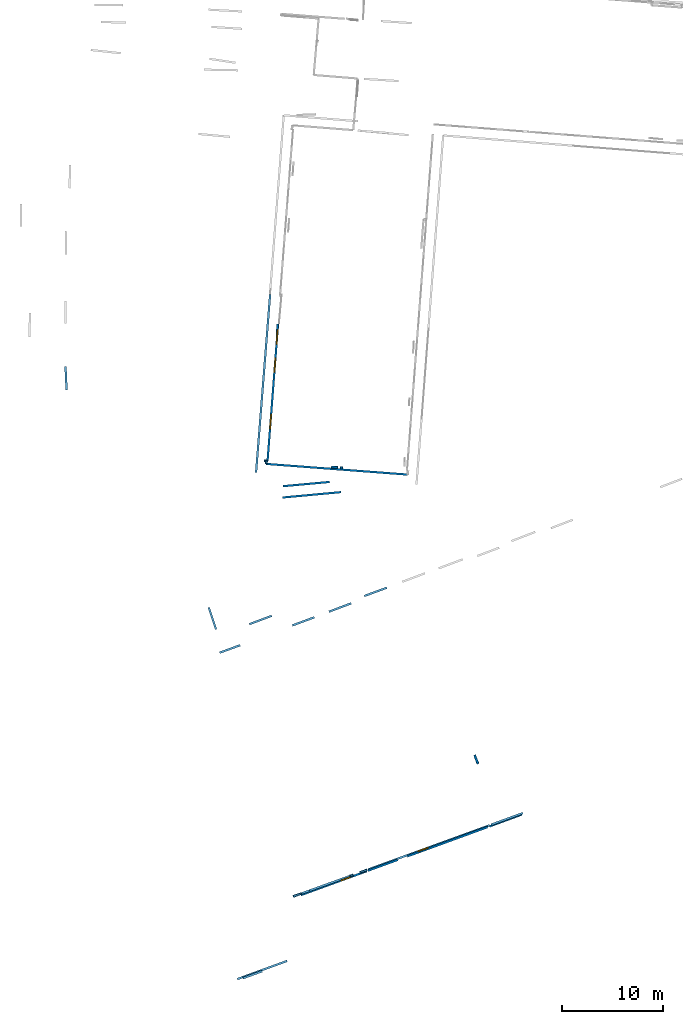
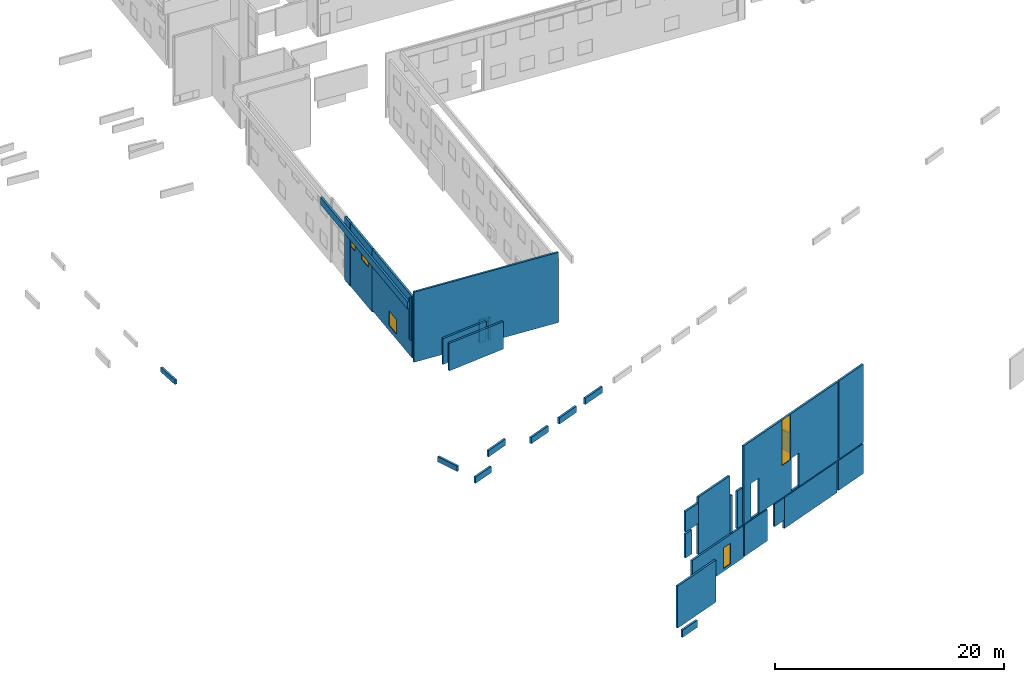
# One storey, part 1 of 27: 33 walls, 5 windows, 7 openings.
"""IFC2X3 building model written with IfcOpenShell, lengths in metres."""

from ifc_helpers import new_model, entity, si_unit, converted_unit, derived_unit, direction, frame, frame_2d, origin, origin_2d_with_axis, place, context, subcontext, project, spatial, polyline, rectangle, outline, extrude, source, transform, mapped, material, layer, layer_set, layer_usage, type_object, type_shapes, element, fill, save


model = new_model("IFC2X3")

# Units and contexts
model_context = context("Model", 3, precision=1e-05, world=origin(), true_north=direction((0.0, 1.0)))
body_context = subcontext(model_context, "Body", "Model", "MODEL_VIEW")
ifc_project = project(units=[si_unit("LENGTHUNIT", "METRE"), si_unit("AREAUNIT", "SQUARE_METRE"), si_unit("VOLUMEUNIT", "CUBIC_METRE"), converted_unit("PLANEANGLEUNIT", "DEGREE", entity("IfcRatioMeasure", 0.0174532925199433), si_unit("PLANEANGLEUNIT", "RADIAN"), dimensions=[0, 0, 0, 0, 0, 0, 0]), si_unit("MASSUNIT", "GRAM", prefix="KILO"), derived_unit("MASSDENSITYUNIT", [(si_unit("MASSUNIT", "GRAM", prefix="KILO"), 1), (si_unit("LENGTHUNIT", "METRE"), -3)]), derived_unit("MOMENTOFINERTIAUNIT", [(si_unit("LENGTHUNIT", "METRE"), 4)]), si_unit("TIMEUNIT", "SECOND"), si_unit("FREQUENCYUNIT", "HERTZ"), si_unit("THERMODYNAMICTEMPERATUREUNIT", "DEGREE_CELSIUS"), derived_unit("THERMALTRANSMITTANCEUNIT", [(si_unit("MASSUNIT", "GRAM", prefix="KILO"), 1), (si_unit("THERMODYNAMICTEMPERATUREUNIT", "KELVIN"), -1), (si_unit("TIMEUNIT", "SECOND"), -3)]), derived_unit("VOLUMETRICFLOWRATEUNIT", [(si_unit("LENGTHUNIT", "METRE"), 3), (si_unit("TIMEUNIT", "SECOND"), -1)]), si_unit("ELECTRICCURRENTUNIT", "AMPERE"), si_unit("ELECTRICVOLTAGEUNIT", "VOLT"), si_unit("POWERUNIT", "WATT"), si_unit("FORCEUNIT", "NEWTON", prefix="KILO"), si_unit("ILLUMINANCEUNIT", "LUX"), si_unit("LUMINOUSFLUXUNIT", "LUMEN"), si_unit("LUMINOUSINTENSITYUNIT", "CANDELA"), derived_unit("USERDEFINED", [(si_unit("MASSUNIT", "GRAM", prefix="KILO"), -1), (si_unit("LENGTHUNIT", "METRE"), -2), (si_unit("TIMEUNIT", "SECOND"), 3), (si_unit("LUMINOUSFLUXUNIT", "LUMEN"), 1)]), derived_unit("LINEARVELOCITYUNIT", [(si_unit("LENGTHUNIT", "METRE"), 1), (si_unit("TIMEUNIT", "SECOND"), -1)]), si_unit("PRESSUREUNIT", "PASCAL"), derived_unit("USERDEFINED", [(si_unit("LENGTHUNIT", "METRE"), -2), (si_unit("MASSUNIT", "GRAM", prefix="KILO"), 1), (si_unit("TIMEUNIT", "SECOND"), -2)]), derived_unit("LINEARFORCEUNIT", [(si_unit("MASSUNIT", "GRAM", prefix="KILO"), 1), (si_unit("LENGTHUNIT", "METRE"), 1), (si_unit("TIMEUNIT", "SECOND"), -2), (si_unit("LENGTHUNIT", "METRE"), -1)]), derived_unit("PLANARFORCEUNIT", [(si_unit("MASSUNIT", "GRAM", prefix="KILO"), 1), (si_unit("LENGTHUNIT", "METRE"), 1), (si_unit("TIMEUNIT", "SECOND"), -2), (si_unit("LENGTHUNIT", "METRE"), -2)])], contexts=[model_context])

# Site, building, storey
placement_1 = place(None, origin())
site = spatial("IfcSite", under=ifc_project, at=placement_1, CompositionType="ELEMENT")
building = spatial("IfcBuilding", under=site, at=placement_1, CompositionType="ELEMENT")
storey_placement = place(placement_1, frame((0.0, 0.0, -61.043098449707)))
storey = spatial("IfcBuildingStorey", under=building, at=storey_placement, Name="level_-61.043098", CompositionType="ELEMENT", Elevation=-61.043098449707)

# Walls
ifc_material_1 = material(Name="Default wall")
ifc_layer = layer(ifc_material_1, 0.2)
ifc_layer_set = layer_set([ifc_layer], Name="wall_thickness_0.2000")
ifc_layer_usage = layer_usage(ifc_layer_set, "AXIS2", "POSITIVE", -0.1)
wall_type = type_object("IfcWallType", Name="wall_thickness_0.2000", PredefinedType="STANDARD", material=ifc_layer_set)
placement_2 = place(placement_1, frame((0.0, 0.0, -60.9578857421875)))
wall_1_placement = place(placement_2, frame((-80.6177598046556, -47.234106704817, 0.0), z_axis=(0.0, 0.0, 1.0), x_axis=(-0.997479703780605, 0.0709523822415854, 0.0)))
element("IfcWallStandardCase", 1, at=wall_1_placement, inside=storey, type_object=wall_type, material=ifc_layer_usage, Name="Wall:151", ObjectType="Wall", context=body_context, shape_type="SweptSolid", body=[
    extrude(outline(polyline([(0.230003199142466, -0.1), (0.230003199142466, 0.1), (0.0, 0.1), (0.0, -0.1), (0.230003199142466, -0.1)])), origin(), (0.0, 0.0, 1.0), 2.42822265625),
])
placement_3 = place(placement_1, frame((0.0, 0.0, -60.8847198486328)))
wall_2_placement = place(placement_3, frame((-108.021425655516, -37.2043182576579, 0.0), z_axis=(0.0, 0.0, 1.0), x_axis=(0.0460349743108002, -0.998939828588391, 0.0)))
element("IfcWallStandardCase", 2, at=wall_2_placement, inside=storey, type_object=wall_type, material=ifc_layer_usage, Name="Wall:236", ObjectType="Wall", context=body_context, shape_type="SweptSolid", body=[
    extrude(outline(polyline([(2.31508790441592, -0.1), (2.31508790441592, 0.1), (0.0, 0.1), (0.0, -0.1), (2.31508790441592, -0.1)])), origin(), (0.0, 0.0, 1.0), 0.486675262451172),
])
placement_4 = place(placement_1, frame((0.0, 0.0, -58.6692237854004)))
wall_3_placement = place(placement_4, frame((-90.4635958246936, -97.7054273782261, 0.0), z_axis=(0.0, 0.0, 1.0), x_axis=(0.939621098176987, 0.342216586185814, 0.0)))
element("IfcWallStandardCase", 3, at=wall_3_placement, inside=storey, type_object=wall_type, material=ifc_layer_usage, Name="Wall:272", ObjectType="Wall", context=body_context, shape_type="SweptSolid", body=[
    extrude(outline(polyline([(2.00499331555158, -0.1), (2.00499331555158, 0.1), (0.0, 0.1), (0.0, -0.1), (2.00499331555158, -0.1)])), origin(), (0.0, 0.0, 1.0), 0.768932342529297),
])
placement_5 = place(placement_1, frame((0.0, 0.0, -56.8473930358887)))
wall_4_placement = place(placement_5, frame((-84.6901072986257, -89.3302330235321, 0.0), z_axis=(0.0, 0.0, 1.0), x_axis=(-0.940651161768594, -0.339375001824521, 0.0)))
element("IfcWallStandardCase", 4, at=wall_4_placement, inside=storey, type_object=wall_type, material=ifc_layer_usage, Name="Wall:330", ObjectType="Wall", context=body_context, shape_type="SweptSolid", body=[
    extrude(outline(polyline([(0.859999959407384, -0.1), (0.859999959407384, 0.1), (0.0, 0.1), (0.0, -0.1), (0.859999959407384, -0.1)])), origin(), (0.0, 0.0, 1.0), 2.56648635864258),
])
placement_6 = place(placement_1, frame((0.0, 0.0, -54.077392578125)))
wall_5_placement = place(placement_6, frame((-83.8764476306569, -89.0366691807587, 0.0), z_axis=(0.0, 0.0, 1.0), x_axis=(-0.940650301479589, -0.339377386291954, 0.0)))
element("IfcWallStandardCase", 5, at=wall_5_placement, inside=storey, type_object=wall_type, material=ifc_layer_usage, Name="Wall:332", ObjectType="Wall", context=body_context, shape_type="SweptSolid", body=[
    extrude(outline(polyline([(1.71499714921871, -0.1), (1.71499714921871, 0.1), (0.0, 0.1), (0.0, -0.1), (1.71499714921871, -0.1)])), origin(), (0.0, 0.0, 1.0), 2.18500137329102),
])
placement_7 = place(placement_1, frame((0.0, 0.0, -57.3973922729492)))
wall_6_placement = place(placement_7, frame((-79.8645762927663, -87.5892128208954, 0.0), z_axis=(0.0, 0.0, 1.0), x_axis=(-0.940649358342172, -0.339380000368998, 0.0)))
element("IfcWallStandardCase", 6, at=wall_6_placement, inside=storey, type_object=wall_type, material=ifc_layer_usage, Name="Wall:333", ObjectType="Wall", context=body_context, shape_type="SweptSolid", body=[
    extrude(outline(polyline([(4.26500193968267, -0.1), (4.26500193968267, 0.1), (0.0, 0.1), (0.0, -0.1), (4.26500193968267, -0.1)])), origin(), (0.0, 0.0, 1.0), 6.125),
])
placement_8 = place(placement_1, frame((0.0, 0.0, -57.4490737915039)))
wall_7_placement = place(placement_8, frame((-62.7970209183944, -81.3764209561319, 0.0), z_axis=(0.0, 0.0, 1.0), x_axis=(-0.938814646743847, -0.344422791143713, 0.0)))
element("IfcWallStandardCase", 7, at=wall_7_placement, inside=storey, type_object=wall_type, material=ifc_layer_usage, Name="Wall:350", ObjectType="Wall", context=body_context, shape_type="SweptSolid", body=[
    extrude(outline(polyline([(3.31500065949104, -0.1), (3.31500065949104, 0.1), (0.0, 0.1), (0.0, -0.1), (3.31500065949104, -0.1)])), origin(), (0.0, 0.0, 1.0), 8.33086395263672),
])
placement_9 = place(placement_1, frame((0.0, 0.0, -60.9578857421875)))
wall_8_placement = place(placement_9, frame((-92.7735247833249, -65.5136680508815, 0.0), z_axis=(0.0, 0.0, 1.0), x_axis=(0.939369104306675, 0.342907692935104, 0.0)))
element("IfcWallStandardCase", 8, at=wall_8_placement, inside=storey, type_object=wall_type, material=ifc_layer_usage, Name="Wall:397", ObjectType="Wall", context=body_context, shape_type="SweptSolid", body=[
    extrude(outline(polyline([(2.15500529948059, -0.1), (2.15500529948059, 0.1), (0.0, 0.1), (0.0, -0.1), (2.15500529948059, -0.1)])), origin(), (0.0, 0.0, 1.0), 0.661750793457031),
])
placement_10 = place(placement_1, frame((0.0, 0.0, -60.9578857421875)))
wall_9_placement = place(placement_10, frame((-81.1078836866677, -47.1977022779575, 0.0), z_axis=(0.0, 0.0, 1.0), x_axis=(-0.997105942992759, 0.0760245910776249, 0.0)))
element("IfcWallStandardCase", 9, at=wall_9_placement, inside=storey, type_object=wall_type, material=ifc_layer_usage, Name="Wall:420", ObjectType="Wall", context=body_context, shape_type="SweptSolid", body=[
    extrude(outline(polyline([(0.610003605423562, -0.1), (0.610003605423562, 0.1), (0.0, 0.1), (0.0, -0.1), (0.610003605423562, -0.1)])), origin(), (0.0, 0.0, 1.0), 2.42822265625),
])
placement_11 = place(placement_1, frame((0.0, 0.0, -57.4490737915039)))
wall_10_placement = place(placement_11, frame((-78.899835847481, -87.2420876099911, 0.0), z_axis=(0.0, 0.0, 1.0), x_axis=(0.939781747473206, 0.341775170420859, 0.0)))
element("IfcWallStandardCase", 10, at=wall_10_placement, inside=storey, type_object=wall_type, material=ifc_layer_usage, Name="Wall:425", ObjectType="Wall", context=body_context, shape_type="SweptSolid", body=[
    extrude(outline(polyline([(0.725001395744502, -0.1), (0.725001395744502, 0.1), (0.0, 0.1), (0.0, -0.1), (0.725001395744502, -0.1)])), origin(), (0.0, 0.0, 1.0), 3.97337341308594),
])

# Wall, openings, window
placement_12 = place(placement_1, frame((0.0, 0.0, -57.4490737915039)))
wall_11_placement = place(placement_12, frame((-78.0822241531451, -86.9447472169247, 0.0), z_axis=(0.0, 0.0, 1.0), x_axis=(0.939780990373428, 0.341777252216614, 0.0)))
wall_11 = element("IfcWallStandardCase", 11, at=wall_11_placement, inside=storey, type_object=wall_type, material=ifc_layer_usage, Name="Wall:426", ObjectType="Wall", context=body_context, shape_type="SweptSolid", body=[
    extrude(outline(polyline([(12.7749968138261, -0.1), (12.7749968138261, 0.1), (0.0, 0.1), (0.0, -0.1), (12.7749968138261, -0.1)])), origin(), (0.0, 0.0, 1.0), 8.33086395263672),
])
opening_1_placement = place(wall_11_placement, frame((0.99500111003798, -0.1, 0.0390853881835938)))
element("IfcOpeningElement", 12, at=opening_1_placement, cuts=wall_11, Name="Opening : 1095 x 3770 : 34", ObjectType="Opening", context=body_context, shape_type="SweptSolid", body=[
    extrude(rectangle(XDim=1.095, YDim=3.77, at=frame_2d((1.885, 0.5475), x_axis=(0.0, 1.0))), frame((0.0, 0.0, 0.0), z_axis=(0.0, 1.0, 0.0), x_axis=(0.0, 0.0, 1.0)), (0.0, 0.0, 1.0), 0.2),
])
opening_2_placement = place(wall_11_placement, frame((6.50500050682698, -0.1, 0.0390853881835938)))
element("IfcOpeningElement", 13, at=opening_2_placement, cuts=wall_11, Name="Opening : 1000 x 3525 : 35", ObjectType="Opening", context=body_context, shape_type="SweptSolid", body=[
    extrude(rectangle(XDim=1.0, YDim=3.525, at=frame_2d((1.7625, 0.5), x_axis=(0.0, 1.0))), frame((0.0, 0.0, 0.0), z_axis=(0.0, 1.0, 0.0), x_axis=(0.0, 0.0, 1.0)), (0.0, 0.0, 1.0), 0.2),
])
opening_3_placement = place(wall_11_placement, frame((5.20499721727004, -0.1, 3.47408294677734)))
opening_3 = element("IfcOpeningElement", 14, at=opening_3_placement, cuts=wall_11, Name="Opening : 1115 x 4845 : 36", ObjectType="Opening", context=body_context, shape_type="SweptSolid", body=[
    extrude(rectangle(XDim=1.115, YDim=4.845, at=frame_2d((2.4225, 0.5575), x_axis=(0.0, 1.0))), frame((0.0, 0.0, 0.0), z_axis=(0.0, 1.0, 0.0), x_axis=(0.0, 0.0, 1.0)), (0.0, 0.0, 1.0), 0.2),
])
ifc_material_2 = material(Name="Window Default")
window_style_1 = type_object("IfcWindowStyle", Name="Window : 1115 x 4845mm", ConstructionType="NOTDEFINED", OperationType="NOTDEFINED", ParameterTakesPrecedence=False, Sizeable=False, material=ifc_material_2)
shared_shape_1 = source(origin(), body_context, "Body", "SweptSolid", [
    extrude(rectangle(XDim=0.1, YDim=1.115, at=origin_2d_with_axis()), frame((0.5575, 0.1, 0.0), z_axis=(0.0, 0.0, 1.0), x_axis=(0.0, 1.0, 0.0)), (0.0, 0.0, 1.0), 4.845),
])
type_shapes(window_style_1, [shared_shape_1])
window_1_placement = place(opening_3_placement, origin())
window_1 = element("IfcWindow", 15, at=window_1_placement, inside=storey, type_object=window_style_1, Name="Window : 1115 x 4845mm : 31", ObjectType="Window : 1115 x 4845mm", OverallHeight=4.845, OverallWidth=1.115, context=body_context, shape_type="MappedRepresentation", body=[
    mapped(shared_shape_1, transform((0.0, 0.0, 0.0), scale=1.0)),
])
fill(opening_3, window_1)

# Walls
placement_13 = place(placement_1, frame((0.0, 0.0, -58.7488288879395)))
wall_12_placement = place(placement_13, frame((-88.0415482907125, -46.5598903433781, 0.0), z_axis=(0.0, 0.0, 1.0), x_axis=(-0.99952273839891, 0.0308916723979706, 0.0)))
element("IfcWallStandardCase", 16, at=wall_12_placement, inside=storey, type_object=wall_type, material=ifc_layer_usage, Name="Wall:614", ObjectType="Wall", context=body_context, shape_type="SweptSolid", body=[
    extrude(outline(polyline([(0.338105395484105, -0.1), (0.338105395484105, 0.1), (0.0, 0.1), (0.0, -0.1), (0.338105395484105, -0.1)])), origin(), (0.0, 0.0, 1.0), 4.46792221069336),
])
placement_14 = place(placement_1, frame((0.0, 0.0, -60.9578857421875)))
wall_13_placement = place(placement_14, frame((-87.1252807965955, -34.133851753987, 0.0), z_axis=(0.0, 0.0, 1.0), x_axis=(0.0750939901580766, 0.997176460132377, 0.0)))
element("IfcWallStandardCase", 17, at=wall_13_placement, inside=storey, type_object=wall_type, material=ifc_layer_usage, Name="Wall:708", ObjectType="Wall", context=body_context, shape_type="SweptSolid", body=[
    extrude(outline(polyline([(1.13596654105524, -0.1), (1.13596654105524, 0.1), (0.0, 0.1), (0.0, -0.1), (1.13596654105524, -0.1)])), origin(), (0.0, 0.0, 1.0), 6.74871063232422),
])
placement_15 = place(placement_1, frame((0.0, 0.0, -57.4490737915039)))
wall_14_placement = place(placement_15, frame((-86.1076475497133, -95.9991330992027, 0.0), z_axis=(0.0, 0.0, 1.0), x_axis=(-0.939519938234223, -0.342494212593968, 0.0)))
element("IfcWallStandardCase", 18, at=wall_14_placement, inside=storey, type_object=wall_type, material=ifc_layer_usage, Name="Wall:722", ObjectType="Wall", context=body_context, shape_type="SweptSolid", body=[
    extrude(outline(polyline([(5.2299993429655, -0.1), (5.2299993429655, 0.1), (0.0, 0.1), (0.0, -0.1), (5.2299993429655, -0.1)])), origin(), (0.0, 0.0, 1.0), 4.48222351074219),
])
placement_16 = place(placement_1, frame((0.0, 0.0, -60.9578857421875)))
wall_15_placement = place(placement_16, frame((-93.8541994151836, -61.0480707435928, 0.0), z_axis=(0.0, 0.0, 1.0), x_axis=(0.316216251807825, -0.948687136042547, 0.0)))
element("IfcWallStandardCase", 19, at=wall_15_placement, inside=storey, type_object=wall_type, material=ifc_layer_usage, Name="Wall:859", ObjectType="Wall", context=body_context, shape_type="SweptSolid", body=[
    extrude(outline(polyline([(2.28599848652367, -0.1), (2.28599848652367, 0.1), (0.0, 0.1), (0.0, -0.1), (2.28599848652367, -0.1)])), origin(), (0.0, 0.0, 1.0), 0.559841156005859),
])
placement_17 = place(placement_1, frame((0.0, 0.0, -60.4365653991699)))
wall_16_placement = place(placement_17, frame((-86.5181115977307, -49.047398770031, 0.0), z_axis=(0.0, 0.0, 1.0), x_axis=(0.995891449344849, 0.0905550723141224, 0.0)))
element("IfcWallStandardCase", 20, at=wall_16_placement, inside=storey, type_object=wall_type, material=ifc_layer_usage, Name="Wall:987", ObjectType="Wall", context=body_context, shape_type="SweptSolid", body=[
    extrude(outline(polyline([(4.64499208321589, -0.1), (4.64499208321589, 0.1), (0.0, 0.1), (0.0, -0.1), (4.64499208321589, -0.1)])), origin(), (0.0, 0.0, 1.0), 2.75803756713867),
])
placement_18 = place(placement_1, frame((0.0, 0.0, -59.860912322998)))
wall_17_placement = place(placement_18, frame((-74.2307634971174, -85.6625388228027, 0.0), z_axis=(0.0, 0.0, 1.0), x_axis=(0.940344920907222, 0.340222617890095, 0.0)))
element("IfcWallStandardCase", 21, at=wall_17_placement, inside=storey, type_object=wall_type, material=ifc_layer_usage, Name="Wall:1031", ObjectType="Wall", context=body_context, shape_type="SweptSolid", body=[
    extrude(outline(polyline([(1.33034609331182, -0.1), (1.33034609331182, 0.1), (0.0, 0.1), (0.0, -0.1), (1.33034609331182, -0.1)])), origin(), (0.0, 0.0, 1.0), 2.40368270874023),
])
placement_19 = place(placement_1, frame((0.0, 0.0, -59.9867630004883)))
wall_18_placement = place(placement_19, frame((-67.231006080947, -76.4951393608299, 0.0), z_axis=(0.0, 0.0, 1.0), x_axis=(-0.362160201809336, 0.932115866309238, 0.0)))
element("IfcWallStandardCase", 22, at=wall_18_placement, inside=storey, type_object=wall_type, material=ifc_layer_usage, Name="Wall:1185", ObjectType="Wall", context=body_context, shape_type="SweptSolid", body=[
    extrude(outline(polyline([(0.910003235915776, -0.1), (0.910003235915776, 0.1), (0.0, 0.1), (0.0, -0.1), (0.910003235915776, -0.1)])), origin(), (0.0, 0.0, 1.0), 2.08647155761719),
])
placement_20 = place(placement_1, frame((0.0, 0.0, -60.8847198486328)))
wall_19_placement = place(placement_20, frame((-81.9654865033188, -61.4609979671343, 0.0), z_axis=(0.0, 0.0, 1.0), x_axis=(0.935510468720207, 0.353298971007415, 0.0)))
element("IfcWallStandardCase", 23, at=wall_19_placement, inside=storey, type_object=wall_type, material=ifc_layer_usage, Name="Wall:1186", ObjectType="Wall", context=body_context, shape_type="SweptSolid", body=[
    extrude(outline(polyline([(2.34755188340901, -0.1), (2.34755188340901, 0.1), (0.0, 0.1), (0.0, -0.1), (2.34755188340901, -0.1)])), origin(), (0.0, 0.0, 1.0), 0.666728973388672),
])
placement_21 = place(placement_1, frame((0.0, 0.0, -60.6535377502441)))
wall_20_placement = place(placement_21, frame((-62.8910993596261, -81.5237194840776, 0.0), z_axis=(0.0, 0.0, 1.0), x_axis=(-0.938565070441642, -0.345102316055509, 0.0)))
element("IfcWallStandardCase", 24, at=wall_20_placement, inside=storey, type_object=wall_type, material=ifc_layer_usage, Name="Wall:1205", ObjectType="Wall", context=body_context, shape_type="SweptSolid", body=[
    extrude(outline(polyline([(3.39999883673861, -0.1), (3.39999883673861, 0.1), (0.0, 0.1), (0.0, -0.1), (3.39999883673861, -0.1)])), origin(), (0.0, 0.0, 1.0), 3.19630813598633),
])
placement_22 = place(placement_1, frame((0.0, 0.0, -57.4490737915039)))
wall_21_placement = place(placement_22, frame((-79.8639438962634, -87.5924108072095, 0.0), z_axis=(0.0, 0.0, 1.0), x_axis=(0.942267349884249, 0.334861525622329, 0.0)))
element("IfcWallStandardCase", 25, at=wall_21_placement, inside=storey, type_object=wall_type, material=ifc_layer_usage, Name="Wall:1310", ObjectType="Wall", context=body_context, shape_type="SweptSolid", body=[
    extrude(outline(polyline([(0.326149092559594, -0.1), (0.326149092559594, 0.1), (0.0, 0.1), (0.0, -0.1), (0.326149092559594, -0.1)])), origin(), (0.0, 0.0, 1.0), 3.97337341308594),
])
placement_23 = place(placement_1, frame((0.0, 0.0, -60.4365653991699)))
wall_22_placement = place(placement_23, frame((-86.5454708725376, -50.1668999550981, 0.0), z_axis=(0.0, 0.0, 1.0), x_axis=(0.995743630293751, 0.0921662776150912, 0.0)))
element("IfcWallStandardCase", 26, at=wall_22_placement, inside=storey, type_object=wall_type, material=ifc_layer_usage, Name="Wall:1323", ObjectType="Wall", context=body_context, shape_type="SweptSolid", body=[
    extrude(outline(polyline([(5.79499799031955, -0.1), (5.79499799031955, 0.1), (0.0, 0.1), (0.0, -0.1), (5.79499799031955, -0.1)])), origin(), (0.0, 0.0, 1.0), 2.93190383911133),
])

# Wall, opening, window
placement_24 = place(placement_1, frame((0.0, 0.0, -60.7575225830078)))
wall_23_placement = place(placement_24, frame((-87.4216198792838, -38.5166913465371, 0.0), z_axis=(0.0, 0.0, 1.0), x_axis=(-0.0768486633173354, -0.997042768865177, 0.0)))
wall_23 = element("IfcWallStandardCase", 27, at=wall_23_placement, inside=storey, type_object=wall_type, material=ifc_layer_usage, Name="Wall:1403", ObjectType="Wall", context=body_context, shape_type="SweptSolid", body=[
    extrude(outline(polyline([(8.06704612240062, -0.1), (8.06704612240062, 0.1), (0.0, 0.1), (0.0, -0.1), (8.06704612240062, -0.1)])), origin(), (0.0, 0.0, 1.0), 6.54834747314453),
])
opening_4_placement = place(wall_23_placement, frame((3.43500108620786, -0.1, 0.563453674316406)))
opening_4 = element("IfcOpeningElement", 28, at=opening_4_placement, cuts=wall_23, Name="Opening : 1450 x 1545 : 228", ObjectType="Opening", context=body_context, shape_type="SweptSolid", body=[
    extrude(rectangle(XDim=1.45, YDim=1.545, at=frame_2d((0.7725, 0.725), x_axis=(0.0, 1.0))), frame((0.0, 0.0, 0.0), z_axis=(0.0, 1.0, 0.0), x_axis=(0.0, 0.0, 1.0)), (0.0, 0.0, 1.0), 0.2),
])
window_style_2 = type_object("IfcWindowStyle", Name="Window : 1450 x 1545mm", ConstructionType="NOTDEFINED", OperationType="NOTDEFINED", ParameterTakesPrecedence=False, Sizeable=False, material=ifc_material_2)
shared_shape_2 = source(origin(), body_context, "Body", "SweptSolid", [
    extrude(rectangle(XDim=0.1, YDim=1.45, at=origin_2d_with_axis()), frame((0.725, 0.1, 0.0), z_axis=(0.0, 0.0, 1.0), x_axis=(0.0, 1.0, 0.0)), (0.0, 0.0, 1.0), 1.545),
])
type_shapes(window_style_2, [shared_shape_2])
window_2_placement = place(opening_4_placement, origin())
window_2 = element("IfcWindow", 29, at=window_2_placement, inside=storey, type_object=window_style_2, Name="Window : 1450 x 1545mm : 211", ObjectType="Window : 1450 x 1545mm", OverallHeight=1.545, OverallWidth=1.45, context=body_context, shape_type="MappedRepresentation", body=[
    mapped(shared_shape_2, transform((0.0, 0.0, 0.0), scale=1.0)),
])
fill(opening_4, window_2)

# Wall, openings, windows
placement_25 = place(placement_1, frame((0.0, 0.0, -60.9578857421875)))
wall_24_placement = place(placement_25, frame((-86.9967236390494, -33.0040112928262, 0.0), z_axis=(0.0, 0.0, 1.0), x_axis=(-0.0768484802822949, -0.997042782972878, 0.0)))
wall_24 = element("IfcWallStandardCase", 30, at=wall_24_placement, inside=storey, type_object=wall_type, material=ifc_layer_usage, Name="Wall:1404", ObjectType="Wall", context=body_context, shape_type="SweptSolid", body=[
    extrude(outline(polyline([(5.49903084008414, -0.1), (5.49903084008414, 0.1), (0.0, 0.1), (0.0, -0.1), (5.49903084008414, -0.1)])), origin(), (0.0, 0.0, 1.0), 6.74871063232422),
])
opening_5_placement = place(wall_24_placement, frame((3.37402983172281, -0.1, 4.30881500244141)))
opening_5 = element("IfcOpeningElement", 31, at=opening_5_placement, cuts=wall_24, Name="Opening : 1425 x 1400 : 229", ObjectType="Opening", context=body_context, shape_type="SweptSolid", body=[
    extrude(rectangle(XDim=1.425, YDim=1.4, at=frame_2d((0.7, 0.7125), x_axis=(0.0, 1.0))), frame((0.0, 0.0, 0.0), z_axis=(0.0, 1.0, 0.0), x_axis=(0.0, 0.0, 1.0)), (0.0, 0.0, 1.0), 0.2),
])
opening_6_placement = place(wall_24_placement, frame((0.579032770710401, -0.1, 4.30381774902344)))
opening_6 = element("IfcOpeningElement", 32, at=opening_6_placement, cuts=wall_24, Name="Opening : 1425 x 1400 : 230", ObjectType="Opening", context=body_context, shape_type="SweptSolid", body=[
    extrude(rectangle(XDim=1.425, YDim=1.4, at=frame_2d((0.7, 0.7125), x_axis=(0.0, 1.0))), frame((0.0, 0.0, 0.0), z_axis=(0.0, 1.0, 0.0), x_axis=(0.0, 0.0, 1.0)), (0.0, 0.0, 1.0), 0.2),
])
window_style_3 = type_object("IfcWindowStyle", Name="Window : 1425 x 1400mm", ConstructionType="NOTDEFINED", OperationType="NOTDEFINED", ParameterTakesPrecedence=False, Sizeable=False, material=ifc_material_2)
shared_shape_3 = source(origin(), body_context, "Body", "SweptSolid", [
    extrude(rectangle(XDim=0.1, YDim=1.425, at=origin_2d_with_axis()), frame((0.7125, 0.1, 0.0), z_axis=(0.0, 0.0, 1.0), x_axis=(0.0, 1.0, 0.0)), (0.0, 0.0, 1.0), 1.4),
])
type_shapes(window_style_3, [shared_shape_3])
window_3_placement = place(opening_5_placement, origin())
window_3 = element("IfcWindow", 33, at=window_3_placement, inside=storey, type_object=window_style_3, Name="Window : 1425 x 1400mm : 212", ObjectType="Window : 1425 x 1400mm", OverallHeight=1.4, OverallWidth=1.425, context=body_context, shape_type="MappedRepresentation", body=[
    mapped(shared_shape_3, transform((0.0, 0.0, 0.0), scale=1.0)),
])
fill(opening_5, window_3)
window_4_placement = place(opening_6_placement, origin())
window_4 = element("IfcWindow", 34, at=window_4_placement, inside=storey, type_object=window_style_3, Name="Window : 1425 x 1400mm : 213", ObjectType="Window : 1425 x 1400mm", OverallHeight=1.4, OverallWidth=1.425, context=body_context, shape_type="MappedRepresentation", body=[
    mapped(shared_shape_3, transform((0.0, 0.0, 0.0), scale=1.0)),
])
fill(opening_6, window_4)

# Wall
placement_26 = place(placement_1, frame((0.0, 0.0, -60.8194160461426)))
wall_25_placement = place(placement_26, frame((-78.1032912013049, -87.0761657484297, 0.0), z_axis=(0.0, 0.0, 1.0), x_axis=(0.939651264135888, 0.342133748419867, 0.0)))
element("IfcWallStandardCase", 35, at=wall_25_placement, inside=storey, type_object=wall_type, material=ifc_layer_usage, Name="Wall:1452", ObjectType="Wall", context=body_context, shape_type="SweptSolid", body=[
    extrude(outline(polyline([(3.12000529434859, -0.1), (3.12000529434859, 0.1), (0.0, 0.1), (0.0, -0.1), (3.12000529434859, -0.1)])), origin(), (0.0, 0.0, 1.0), 3.36218643188477),
])

# Wall, opening, window
placement_27 = place(placement_1, frame((0.0, 0.0, -60.8847198486328)))
wall_26_placement = place(placement_27, frame((-84.7419249293322, -89.4933334120039, 0.0), z_axis=(0.0, 0.0, 1.0), x_axis=(0.939651480388224, 0.342133154494297, 0.0)))
wall_26 = element("IfcWallStandardCase", 36, at=wall_26_placement, inside=storey, type_object=wall_type, material=ifc_layer_usage, Name="Wall:1453", ObjectType="Wall", context=body_context, shape_type="SweptSolid", body=[
    extrude(outline(polyline([(6.91999974054398, -0.1), (6.91999974054398, 0.1), (0.0, 0.1), (0.0, -0.1), (6.91999974054398, -0.1)])), origin(), (0.0, 0.0, 1.0), 3.427490234375),
])
opening_7_placement = place(wall_26_placement, frame((4.22499615814409, -0.1, 0.30596923828125)))
opening_7 = element("IfcOpeningElement", 37, at=opening_7_placement, cuts=wall_26, Name="Opening : 960 x 2200 : 233", ObjectType="Opening", context=body_context, shape_type="SweptSolid", body=[
    extrude(rectangle(XDim=0.96, YDim=2.2, at=frame_2d((1.1, 0.48), x_axis=(0.0, 1.0))), frame((0.0, 0.0, 0.0), z_axis=(0.0, 1.0, 0.0), x_axis=(0.0, 0.0, 1.0)), (0.0, 0.0, 1.0), 0.2),
])
window_style_4 = type_object("IfcWindowStyle", Name="Window : 960 x 2200mm", ConstructionType="NOTDEFINED", OperationType="NOTDEFINED", ParameterTakesPrecedence=False, Sizeable=False, material=ifc_material_2)
shared_shape_4 = source(origin(), body_context, "Body", "SweptSolid", [
    extrude(rectangle(XDim=0.1, YDim=0.96, at=origin_2d_with_axis()), frame((0.48, 0.1, 0.0), z_axis=(0.0, 0.0, 1.0), x_axis=(0.0, 1.0, 0.0)), (0.0, 0.0, 1.0), 2.2),
])
type_shapes(window_style_4, [shared_shape_4])
window_5_placement = place(opening_7_placement, origin())
window_5 = element("IfcWindow", 38, at=window_5_placement, inside=storey, type_object=window_style_4, Name="Window : 960 x 2200mm : 216", ObjectType="Window : 960 x 2200mm", OverallHeight=2.2, OverallWidth=0.96, context=body_context, shape_type="MappedRepresentation", body=[
    mapped(shared_shape_4, transform((0.0, 0.0, 0.0), scale=1.0)),
])
fill(opening_7, window_5)

# Walls
placement_28 = place(placement_1, frame((0.0, 0.0, -58.7488288879395)))
wall_27_placement = place(placement_28, frame((-88.1799873677354, -46.8436637853812, 0.0), z_axis=(0.0, 0.0, 1.0), x_axis=(0.0823271183770588, 0.996605361002905, 0.0)))
element("IfcWallStandardCase", 39, at=wall_27_placement, inside=storey, type_object=wall_type, material=ifc_layer_usage, Name="Wall:1515", ObjectType="Wall", context=body_context, shape_type="SweptSolid", body=[
    extrude(outline(polyline([(0.288301678166507, -0.1), (0.288301678166507, 0.1), (0.0, 0.1), (0.0, -0.1), (0.288301678166507, -0.1)])), origin(), (0.0, 0.0, 1.0), 4.53965377807617),
])
placement_29 = place(placement_1, frame((0.0, 0.0, -60.7575225830078)))
wall_28_placement = place(placement_29, frame((-72.9787941492429, -85.2117675226229, 0.0), z_axis=(0.0, 0.0, 1.0), x_axis=(0.939315244315762, 0.343055202257625, 0.0)))
element("IfcWallStandardCase", 40, at=wall_28_placement, inside=storey, type_object=wall_type, material=ifc_layer_usage, Name="Wall:1528", ObjectType="Wall", context=body_context, shape_type="SweptSolid", body=[
    extrude(outline(polyline([(7.13500475835992, -0.1), (7.13500475835992, 0.1), (0.0, 0.1), (0.0, -0.1), (7.13500475835992, -0.1)])), origin(), (0.0, 0.0, 1.0), 3.30029296875),
])
placement_30 = place(placement_1, frame((0.0, 0.0, -60.9578857421875)))
wall_29_placement = place(placement_30, frame((-88.179987091081, -46.843658402959, 0.0), z_axis=(0.0, 0.0, 1.0), x_axis=(0.997162308466442, -0.0752816748875641, 0.0)))
element("IfcWallStandardCase", 41, at=wall_29_placement, inside=storey, type_object=wall_type, material=ifc_layer_usage, Name="Wall:1789", ObjectType="Wall", context=body_context, shape_type="SweptSolid", body=[
    extrude(outline(polyline([(14.0360304863995, -0.1), (14.0360304863995, 0.1), (0.0, 0.1), (0.0, -0.1), (14.0360304863995, -0.1)])), origin(), (0.0, 0.0, 1.0), 7.48218536376953),
])
placement_31 = place(placement_1, frame((0.0, 0.0, -60.9578857421875)))
wall_30_placement = place(placement_31, frame((-78.4607080124437, -59.9054041465094, 0.0), z_axis=(0.0, 0.0, 1.0), x_axis=(0.937985815018529, 0.346673637336366, 0.0)))
element("IfcWallStandardCase", 42, at=wall_30_placement, inside=storey, type_object=wall_type, material=ifc_layer_usage, Name="Wall:1793", ObjectType="Wall", context=body_context, shape_type="SweptSolid", body=[
    extrude(outline(polyline([(2.35999937271425, -0.1), (2.35999937271425, 0.1), (0.0, 0.1), (0.0, -0.1), (2.35999937271425, -0.1)])), origin(), (0.0, 0.0, 1.0), 0.661750793457031),
])
placement_32 = place(placement_1, frame((0.0, 0.0, -60.8847198486328)))
wall_31_placement = place(placement_32, frame((-89.8336567782858, -62.6909591155598, 0.0), z_axis=(0.0, 0.0, 1.0), x_axis=(0.936423735998846, 0.350871182427346, 0.0)))
element("IfcWallStandardCase", 43, at=wall_31_placement, inside=storey, type_object=wall_type, material=ifc_layer_usage, Name="Wall:1817", ObjectType="Wall", context=body_context, shape_type="SweptSolid", body=[
    extrude(outline(polyline([(2.36000098304078, -0.1), (2.36000098304078, 0.1), (0.0, 0.1), (0.0, -0.1), (2.36000098304078, -0.1)])), origin(), (0.0, 0.0, 1.0), 0.666728973388672),
])
placement_33 = place(placement_1, frame((0.0, 0.0, -60.8847198486328)))
wall_32_placement = place(placement_33, frame((-85.5834174299405, -62.8176918343463, 0.0), z_axis=(0.0, 0.0, 1.0), x_axis=(0.937805194107813, 0.347161947661904, 0.0)))
element("IfcWallStandardCase", 44, at=wall_32_placement, inside=storey, type_object=wall_type, material=ifc_layer_usage, Name="Wall:1832", ObjectType="Wall", context=body_context, shape_type="SweptSolid", body=[
    extrude(outline(polyline([(2.31522123689073, -0.1), (2.31522123689073, 0.1), (0.0, 0.1), (0.0, -0.1), (2.31522123689073, -0.1)])), origin(), (0.0, 0.0, 1.0), 0.666728973388672),
])
placement_34 = place(placement_1, frame((0.0, 0.0, -54.4207000732422)))
wall_33_placement = place(placement_34, frame((-89.1759683959067, -47.6983356908561, 0.0), z_axis=(0.0, 0.0, 1.0), x_axis=(0.0787238155620185, 0.996896464465271, 0.0)))
element("IfcWallStandardCase", 45, at=wall_33_placement, inside=storey, type_object=wall_type, material=ifc_layer_usage, Name="Wall:1860", ObjectType="Wall", context=body_context, shape_type="SweptSolid", body=[
    extrude(outline(polyline([(17.6773962255653, -0.1), (17.6773962255653, 0.1), (0.0, 0.1), (0.0, -0.1), (17.6773962255653, -0.1)])), origin(), (0.0, 0.0, 1.0), 0.772296905517578),
])

save(model, "model.ifc")
